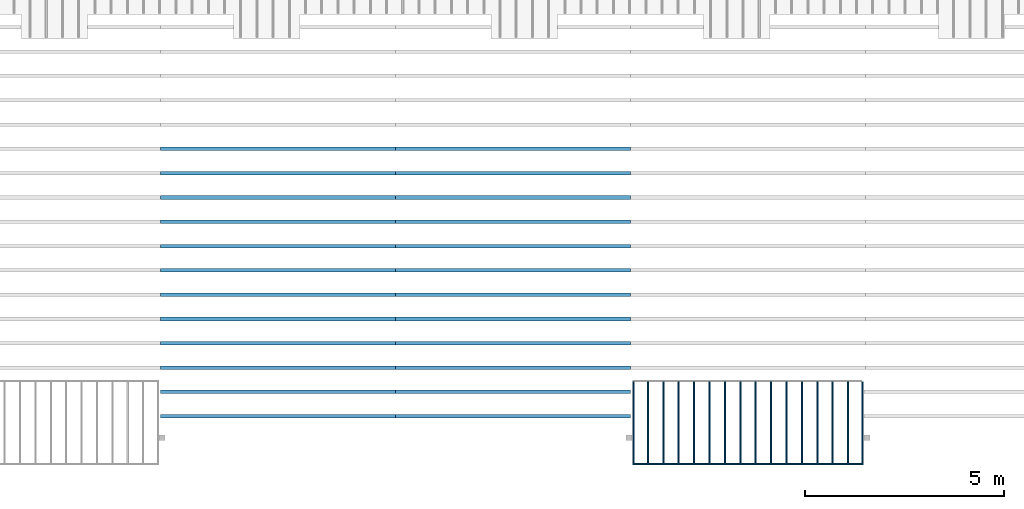
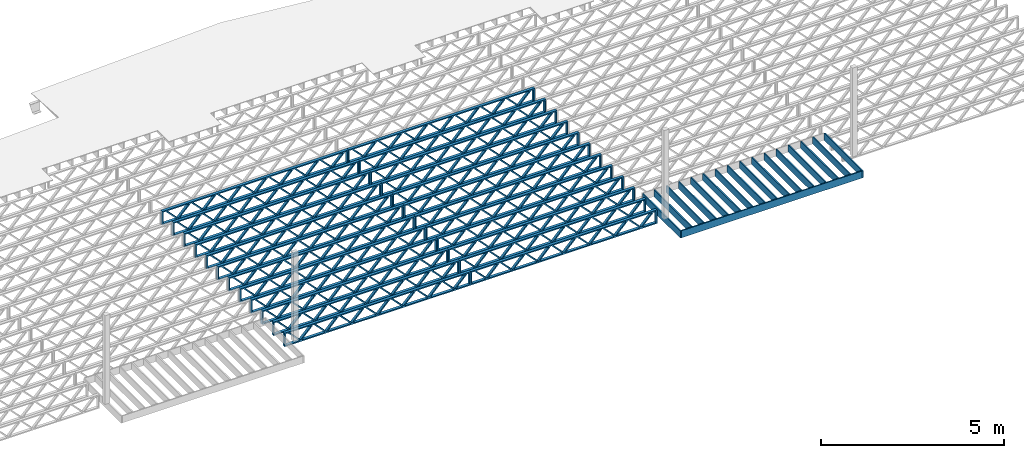
# One storey, part 6 of 12: 41 beams, 3 elements without a shape of their own.
"""IFC4 building model written with IfcOpenShell, lengths in feet."""

import ifcopenshell
import ifcopenshell.guid

model = None  # the IFC model being written
_history = None  # IfcOwnerHistory: only IFC2X3 demands one
_inside = {}  # id of a spatial element -> (the spatial element, [elements in it])
_under = {}  # id of a project, library or spatial element -> (it, [spatial elements below it])
_declared = {}  # id of a project -> (the project, [libraries it declares])
_typed = {}  # id of a type object -> (the type object, [elements of that type])
_made_of = {}  # id of a material, layer set ... -> (it, [elements and type objects made of it])


def new_model(schema):
    """Start an empty IFC model of exactly this schema.

    Asked for "IFC4X3", IfcOpenShell would pick the latest addendum, in which some entities
    have other attributes; the version numbers below select the first issue.
    IFC2X3 requires an IfcOwnerHistory on every rooted entity: one is made here for all.
    """
    global model, _history
    if schema == "IFC4X3":
        model = ifcopenshell.file(schema_version=(4, 3, 0, 0))
    else:
        model = ifcopenshell.file(schema=schema)
    _inside.clear()
    _under.clear()
    _declared.clear()
    _typed.clear()
    _made_of.clear()
    _history = None
    if model.schema == "IFC2X3":
        org = make("IfcOrganization", Name="unknown")
        user = make(
            "IfcPersonAndOrganization",
            ThePerson=make("IfcPerson", FamilyName="unknown"),
            TheOrganization=org,
        )
        app = make(
            "IfcApplication",
            ApplicationDeveloper=org,
            Version="unknown",
            ApplicationFullName="unknown",
            ApplicationIdentifier="unknown",
        )
        _history = make(
            "IfcOwnerHistory",
            OwningUser=user,
            OwningApplication=app,
            ChangeAction="ADDED",
            CreationDate=0,
        )
    return model


def make(cls, **values):
    """One entity of the class cls with the attributes given. An attribute that is None is left unset."""
    return model.create_entity(
        cls, **{name: value for name, value in values.items() if value is not None}
    )


def entity(cls, *values):
    """Any entity or typed value of the class cls, its attributes in the order of the schema. None: left unset."""
    e = model.create_entity(cls)
    for i, value in enumerate(values):
        if value is not None:
            e[i] = value
    return e


def rooted(cls, **values):
    """An entity with a GlobalId (a new one), such as an element, a storey or a relation."""
    return make(cls, GlobalId=ifcopenshell.guid.new(), OwnerHistory=_history, **values)


def si_unit(unit_type, name, prefix=None):
    """IfcSIUnit, for example si_unit("LENGTHUNIT", "METRE", prefix="MILLI")."""
    return make("IfcSIUnit", UnitType=unit_type, Prefix=prefix, Name=name)


def converted_unit(unit_type, name, factor, base, dimensions=None, offset=None):
    """IfcConversionBasedUnit, such as the inch: factor (a typed value) times the base unit."""
    return make(
        "IfcConversionBasedUnit"
        if offset is None
        else "IfcConversionBasedUnitWithOffset",
        ConversionOffset=offset,
        Dimensions=None
        if dimensions is None
        else entity("IfcDimensionalExponents", *dimensions),
        UnitType=unit_type,
        Name=name,
        ConversionFactor=make(
            "IfcMeasureWithUnit", ValueComponent=factor, UnitComponent=base
        ),
    )


def derived_unit(unit_type, elements):
    """IfcDerivedUnit: a product of units, each with its exponent."""
    return make(
        "IfcDerivedUnit",
        Elements=[
            make("IfcDerivedUnitElement", Unit=unit, Exponent=power)
            for unit, power in elements
        ],
        UnitType=unit_type,
    )


def assignment(units):
    """IfcUnitAssignment: the units of a project."""
    return None if units is None else make("IfcUnitAssignment", Units=units)


def point(xyz):
    """IfcCartesianPoint."""
    return None if xyz is None else make("IfcCartesianPoint", Coordinates=xyz)


def direction(xyz):
    """IfcDirection."""
    return None if xyz is None else make("IfcDirection", DirectionRatios=xyz)


def frame(location, z_axis=None, x_axis=None):
    """IfcAxis2Placement3D, a coordinate frame: its origin and axes. An axis left out is left unset."""
    return make(
        "IfcAxis2Placement3D",
        Location=point(location),
        Axis=direction(z_axis),
        RefDirection=direction(x_axis),
    )


def frame_2d(location, x_axis=None):
    """IfcAxis2Placement2D, a coordinate frame in the plane: its origin and x axis."""
    return make(
        "IfcAxis2Placement2D", Location=point(location), RefDirection=direction(x_axis)
    )


def origin():
    """The frame at (0, 0, 0) with its axes left unset."""
    return frame((0.0, 0.0, 0.0))


def origin_2d_with_axis():
    """The frame at (0, 0) in the plane with the x axis (1, 0) written out."""
    return frame_2d((0.0, 0.0), x_axis=(1.0, 0.0))


def place(relative_to, where):
    """IfcLocalPlacement: puts the frame where relative to a parent placement (None: the world)."""
    return make(
        "IfcLocalPlacement", PlacementRelTo=relative_to, RelativePlacement=where
    )


def context(
    kind, dimensions, precision=None, world=None, true_north=None, identifier=None
):
    """IfcGeometricRepresentationContext, for example the 3D "Model" context."""
    return make(
        "IfcGeometricRepresentationContext",
        ContextIdentifier=identifier,
        ContextType=kind,
        CoordinateSpaceDimension=dimensions,
        Precision=precision,
        WorldCoordinateSystem=world,
        TrueNorth=true_north,
    )


def subcontext(parent, identifier, kind, view, scale=None):
    """IfcGeometricRepresentationSubContext, for example "Body" below "Model"."""
    return make(
        "IfcGeometricRepresentationSubContext",
        ContextIdentifier=identifier,
        ContextType=kind,
        ParentContext=parent,
        TargetScale=scale,
        TargetView=view,
    )


def project(units=None, contexts=None):
    """IfcProject with its units and contexts."""
    return rooted(
        "IfcProject",
        Name="project",
        RepresentationContexts=contexts,
        UnitsInContext=assignment(units),
    )


def spatial(cls, under=None, at=None, **own):
    """A site, building, storey or space (cls), placed at a placement, below another one or the project."""
    s = rooted(cls, ObjectPlacement=at, **own)
    if under is not None:
        _under.setdefault(under.id(), (under, []))[1].append(s)
    return s


def profile(cls, at=None, kind="AREA", **sizes):
    """A parametric profile (cls). Its sizes go by their IFC names, for example OverallWidth=200.0."""
    return make(cls, ProfileType=kind, Position=at, **sizes)


def rectangle(**sizes):
    """IfcRectangleProfileDef."""
    return profile("IfcRectangleProfileDef", **sizes)


def extrude(swept, where, along, depth):
    """IfcExtrudedAreaSolid: the profile swept, set in the frame where, extruded along a direction by depth."""
    return make(
        "IfcExtrudedAreaSolid",
        SweptArea=swept,
        Position=where,
        ExtrudedDirection=direction(along),
        Depth=depth,
    )


def shape(context_of_items, identifier, shape_type, items):
    """IfcShapeRepresentation: the items that make up one representation, for example the "Body"."""
    return make(
        "IfcShapeRepresentation",
        ContextOfItems=context_of_items,
        RepresentationIdentifier=identifier,
        RepresentationType=shape_type,
        Items=items,
    )


def source(mapping_origin, context_of_items, identifier, shape_type, items):
    """IfcRepresentationMap: a shape defined once, which mapped items show again and again."""
    return make(
        "IfcRepresentationMap",
        MappingOrigin=mapping_origin,
        MappedRepresentation=shape(context_of_items, identifier, shape_type, items),
    )


def transform(
    local_origin,
    x_axis=None,
    y_axis=None,
    z_axis=None,
    scale=None,
    scale2=None,
    scale3=None,
    uniform=True,
):
    """IfcCartesianTransformationOperator3D, or its non-uniform kind. x_axis, y_axis, z_axis: its Axis1, 2, 3."""
    if uniform:
        return make(
            "IfcCartesianTransformationOperator3D",
            Axis1=direction(x_axis),
            Axis2=direction(y_axis),
            LocalOrigin=point(local_origin),
            Scale=scale,
            Axis3=direction(z_axis),
        )
    return make(
        "IfcCartesianTransformationOperator3DnonUniform",
        Axis1=direction(x_axis),
        Axis2=direction(y_axis),
        LocalOrigin=point(local_origin),
        Scale=scale,
        Axis3=direction(z_axis),
        Scale2=scale2,
        Scale3=scale3,
    )


def mapped(mapping_source, mapping_target):
    """IfcMappedItem: shows the shape of a source again, moved by a transform."""
    return make(
        "IfcMappedItem", MappingSource=mapping_source, MappingTarget=mapping_target
    )


def material(Name=None, Category=None):
    """IfcMaterial."""
    return make("IfcMaterial", Name=Name, Category=Category)


def material_profile(
    of_material, cross_section, Name=None, Category=None, Priority=None
):
    """IfcMaterialProfile: a cross section and its material."""
    return make(
        "IfcMaterialProfile",
        Name=Name,
        Material=of_material,
        Profile=cross_section,
        Priority=Priority,
        Category=Category,
    )


def profile_set(profiles, Name=None, composite=None):
    """IfcMaterialProfileSet."""
    return make(
        "IfcMaterialProfileSet",
        Name=Name,
        MaterialProfiles=profiles,
        CompositeProfile=composite,
    )


def profile_usage(for_profile_set, cardinal=None, extent=None):
    """IfcMaterialProfileSetUsage: how a profile set lies along its element."""
    return make(
        "IfcMaterialProfileSetUsage",
        ForProfileSet=for_profile_set,
        CardinalPoint=cardinal,
        ReferenceExtent=extent,
    )


def made_of(thing, what):
    """Note that an element or type object is made of a material, layer set ...; save() writes the relation."""
    if what is not None:
        _made_of.setdefault(what.id(), (what, []))[1].append(thing)
    return thing


def type_object(cls, material=None, **own):
    """A type object (cls), such as IfcWallType, which elements share."""
    return made_of(rooted(cls, **own), material)


def type_shapes(of_type, sources):
    """Give a type object the sources (RepresentationMaps) that its elements show as mapped items."""
    of_type.RepresentationMaps = sources


def element(
    cls,
    number,
    at=None,
    inside=None,
    cuts=None,
    type_object=None,
    material=None,
    context=None,
    identifier="Body",
    shape_type=None,
    held_by="IfcProductDefinitionShape",
    body=None,
    shapes=None,
    **own,
):
    """One element of the class cls, such as IfcWall. Its Tag is "e" and its number.

    at: its placement. inside: the storey or other place that contains it. cuts: it is an
    opening in that element (IfcRelVoidsElement). A single representation is given by context,
    identifier, shape_type and body (its items); several are given by shapes. held_by: the class
    of the entity that holds the representations. save() writes the other relations.
    """
    e = rooted(cls, Tag="e%d" % number, ObjectPlacement=at, **own)
    if body is not None:
        shapes = [shape(context, identifier, shape_type, body)]
    if shapes is not None:
        e.Representation = make(held_by, Representations=shapes)
    if inside is not None:
        _inside.setdefault(inside.id(), (inside, []))[1].append(e)
    if cuts is not None:
        rooted(
            "IfcRelVoidsElement", RelatingBuildingElement=cuts, RelatedOpeningElement=e
        )
    if type_object is not None:
        _typed.setdefault(type_object.id(), (type_object, []))[1].append(e)
    return made_of(e, material)


def aggregate(whole, parts):
    """IfcRelAggregates: a whole, such as a stair, and the parts it consists of."""
    return rooted("IfcRelAggregates", RelatingObject=whole, RelatedObjects=parts)


def save(model, path):
    """Write the relations noted so far, then the file.

    IfcRelAggregates (storeys below a building ...), IfcRelContainedInSpatialStructure (elements
    in a storey), IfcRelDefinesByType, IfcRelAssociatesMaterial and IfcRelDeclares: one each for
    every whole, place, type object, material and project.
    """
    for whole, parts in _under.values():
        aggregate(whole, parts)
    for where, things in _inside.values():
        rooted(
            "IfcRelContainedInSpatialStructure",
            RelatedElements=things,
            RelatingStructure=where,
        )
    for kind, things in _typed.values():
        rooted("IfcRelDefinesByType", RelatedObjects=things, RelatingType=kind)
    for what, things in _made_of.values():
        rooted("IfcRelAssociatesMaterial", RelatedObjects=things, RelatingMaterial=what)
    for by, libraries in _declared.values():
        rooted("IfcRelDeclares", RelatingContext=by, RelatedDefinitions=libraries)
    model.write(path)


model = new_model("IFC4")

# Units and contexts
model_context = context("Model", 3, precision=0.0001, world=origin(), true_north=direction((6.12303176911189e-17, 1.0)))
body_context = subcontext(model_context, "Body", "Model", "MODEL_VIEW")
ifc_project = project(units=[converted_unit("LENGTHUNIT", "FOOT", entity("IfcRatioMeasure", 0.3048), si_unit("LENGTHUNIT", "METRE"), dimensions=[1, 0, 0, 0, 0, 0, 0]), converted_unit("AREAUNIT", "SQUARE FOOT", entity("IfcRatioMeasure", 0.09290304), si_unit("AREAUNIT", "SQUARE_METRE"), dimensions=[2, 0, 0, 0, 0, 0, 0]), converted_unit("VOLUMEUNIT", "CUBIC FOOT", entity("IfcRatioMeasure", 0.028316846592), si_unit("VOLUMEUNIT", "CUBIC_METRE"), dimensions=[3, 0, 0, 0, 0, 0, 0]), converted_unit("PLANEANGLEUNIT", "DEGREE", entity("IfcRatioMeasure", 0.0174532925199433), si_unit("PLANEANGLEUNIT", "RADIAN"), dimensions=[0, 0, 0, 0, 0, 0, 0]), si_unit("MASSUNIT", "GRAM", prefix="KILO"), derived_unit("MASSDENSITYUNIT", [(si_unit("MASSUNIT", "GRAM", prefix="KILO"), 1), (si_unit("LENGTHUNIT", "METRE"), -3)]), derived_unit("MOMENTOFINERTIAUNIT", [(si_unit("LENGTHUNIT", "METRE"), 4)]), si_unit("TIMEUNIT", "SECOND"), si_unit("FREQUENCYUNIT", "HERTZ"), si_unit("THERMODYNAMICTEMPERATUREUNIT", "DEGREE_CELSIUS"), derived_unit("THERMALTRANSMITTANCEUNIT", [(si_unit("MASSUNIT", "GRAM", prefix="KILO"), 1), (si_unit("THERMODYNAMICTEMPERATUREUNIT", "KELVIN"), -1), (si_unit("TIMEUNIT", "SECOND"), -3)]), derived_unit("VOLUMETRICFLOWRATEUNIT", [(si_unit("LENGTHUNIT", "METRE"), 3), (si_unit("TIMEUNIT", "SECOND"), -1)]), si_unit("ELECTRICCURRENTUNIT", "AMPERE"), si_unit("ELECTRICVOLTAGEUNIT", "VOLT"), si_unit("POWERUNIT", "WATT"), si_unit("FORCEUNIT", "NEWTON"), si_unit("ILLUMINANCEUNIT", "LUX"), si_unit("LUMINOUSFLUXUNIT", "LUMEN"), si_unit("LUMINOUSINTENSITYUNIT", "CANDELA"), derived_unit("USERDEFINED", [(si_unit("MASSUNIT", "GRAM", prefix="KILO"), -1), (si_unit("LENGTHUNIT", "METRE"), -2), (si_unit("TIMEUNIT", "SECOND"), 3), (si_unit("LUMINOUSFLUXUNIT", "LUMEN"), 1)]), derived_unit("LINEARVELOCITYUNIT", [(si_unit("LENGTHUNIT", "METRE"), 1), (si_unit("TIMEUNIT", "SECOND"), -1)]), si_unit("PRESSUREUNIT", "PASCAL"), derived_unit("USERDEFINED", [(si_unit("LENGTHUNIT", "METRE"), -2), (si_unit("MASSUNIT", "GRAM", prefix="KILO"), 1), (si_unit("TIMEUNIT", "SECOND"), -2)]), derived_unit("LINEARFORCEUNIT", [(si_unit("MASSUNIT", "GRAM", prefix="KILO"), 1), (si_unit("LENGTHUNIT", "METRE"), 1), (si_unit("TIMEUNIT", "SECOND"), -2), (si_unit("LENGTHUNIT", "METRE"), -1)]), derived_unit("PLANARFORCEUNIT", [(si_unit("MASSUNIT", "GRAM", prefix="KILO"), 1), (si_unit("LENGTHUNIT", "METRE"), 1), (si_unit("TIMEUNIT", "SECOND"), -2), (si_unit("LENGTHUNIT", "METRE"), -2)])], contexts=[model_context])

# Site, building, storey
site_placement = place(None, origin())
site = spatial("IfcSite", under=ifc_project, at=site_placement, CompositionType="ELEMENT")
building_placement = place(site_placement, origin())
building = spatial("IfcBuilding", under=site, at=building_placement, CompositionType="ELEMENT")
storey_placement = place(building_placement, frame((0.0, 0.0, 21.46875)))
storey = spatial("IfcBuildingStorey", under=building, at=storey_placement, Name="3RD FLOOR", CompositionType="ELEMENT", Elevation=21.46875)

# Assembly, beams
assembly_1_placement = place(storey_placement, origin())
assembly_1 = element("IfcElementAssembly", 1, at=assembly_1_placement, inside=storey, Name="Structural Beam System:Structural Framing System", ObjectType="Structural Beam System:Structural Framing System", AssemblyPlace="NOTDEFINED", PredefinedType="BEAM_GRID")
ifc_material_1 = material(Category="Materials")
ifc_material_profile_1 = material_profile(ifc_material_1, rectangle(XDim=0.770833333333333, YDim=0.124999999999994, at=frame_2d((-5.55111512312578e-17, 0.0), x_axis=(1.0, 0.0))))
ifc_profile_set_1 = profile_set([ifc_material_profile_1])
ifc_profile_usage_1 = profile_usage(ifc_profile_set_1, cardinal=8)
beam_type_1 = type_object("IfcBeamType", PredefinedType="BEAM", material=ifc_profile_set_1)
shared_shape_1 = source(origin(), body_context, "Body", "SweptSolid", [
    extrude(rectangle(XDim=0.770833333333333, YDim=0.124999999999994, at=frame_2d((-5.55111512312578e-17, 0.0), x_axis=(1.0, 0.0))), frame((-3.35416666666737, 0.0, 0.0), z_axis=(1.0, 0.0, 0.0), x_axis=(0.0, 0.0, -1.0)), (0.0, 0.0, 1.0), 6.70833333333462),
])
type_shapes(beam_type_1, [shared_shape_1])
beam_1_placement = place(assembly_1_placement, frame((-165.835122291113, 925.341101549316, -0.645833333333474), z_axis=(0.0, 0.0, 1.0), x_axis=(0.0, 1.0, 0.0)))
beam_1 = element("IfcBeam", 2, at=beam_1_placement, type_object=beam_type_1, material=ifc_profile_usage_1, PredefinedType="BEAM", context=body_context, shape_type="MappedRepresentation", body=[
    mapped(shared_shape_1, transform((0.0, 0.0, 0.0), scale=1.0)),
])
ifc_profile_usage_2 = profile_usage(ifc_profile_set_1, cardinal=8)
beam_2_placement = place(assembly_1_placement, frame((-167.102005971671, 925.341101549316, -0.645833333333474), z_axis=(0.0, 0.0, 1.0), x_axis=(0.0, 1.0, 0.0)))
beam_2 = element("IfcBeam", 3, at=beam_2_placement, type_object=beam_type_1, material=ifc_profile_usage_2, PredefinedType="BEAM", context=body_context, shape_type="MappedRepresentation", body=[
    mapped(shared_shape_1, transform((0.0, 0.0, 0.0), scale=1.0)),
])
ifc_profile_usage_3 = profile_usage(ifc_profile_set_1, cardinal=8)
beam_3_placement = place(assembly_1_placement, frame((-168.368889652229, 925.341101549316, -0.645833333333474), z_axis=(0.0, 0.0, 1.0), x_axis=(0.0, 1.0, 0.0)))
beam_3 = element("IfcBeam", 4, at=beam_3_placement, type_object=beam_type_1, material=ifc_profile_usage_3, PredefinedType="BEAM", context=body_context, shape_type="MappedRepresentation", body=[
    mapped(shared_shape_1, transform((0.0, 0.0, 0.0), scale=1.0)),
])
ifc_profile_usage_4 = profile_usage(ifc_profile_set_1, cardinal=8)
beam_4_placement = place(assembly_1_placement, frame((-169.635773332788, 925.341101549317, -0.645833333333474), z_axis=(0.0, 0.0, 1.0), x_axis=(0.0, 1.0, 0.0)))
beam_4 = element("IfcBeam", 5, at=beam_4_placement, type_object=beam_type_1, material=ifc_profile_usage_4, PredefinedType="BEAM", context=body_context, shape_type="MappedRepresentation", body=[
    mapped(shared_shape_1, transform((0.0, 0.0, 0.0), scale=1.0)),
])
ifc_profile_usage_5 = profile_usage(ifc_profile_set_1, cardinal=8)
beam_5_placement = place(assembly_1_placement, frame((-170.902657013346, 925.341101549317, -0.645833333333474), z_axis=(0.0, 0.0, 1.0), x_axis=(0.0, 1.0, 0.0)))
beam_5 = element("IfcBeam", 6, at=beam_5_placement, type_object=beam_type_1, material=ifc_profile_usage_5, PredefinedType="BEAM", context=body_context, shape_type="MappedRepresentation", body=[
    mapped(shared_shape_1, transform((0.0, 0.0, 0.0), scale=1.0)),
])
ifc_profile_usage_6 = profile_usage(ifc_profile_set_1, cardinal=8)
beam_6_placement = place(assembly_1_placement, frame((-172.169540693904, 925.341101549317, -0.645833333333474), z_axis=(0.0, 0.0, 1.0), x_axis=(0.0, 1.0, 0.0)))
beam_6 = element("IfcBeam", 7, at=beam_6_placement, type_object=beam_type_1, material=ifc_profile_usage_6, PredefinedType="BEAM", context=body_context, shape_type="MappedRepresentation", body=[
    mapped(shared_shape_1, transform((0.0, 0.0, 0.0), scale=1.0)),
])
ifc_profile_usage_7 = profile_usage(ifc_profile_set_1, cardinal=8)
beam_7_placement = place(assembly_1_placement, frame((-173.436424374463, 925.341101549317, -0.645833333333474), z_axis=(0.0, 0.0, 1.0), x_axis=(0.0, 1.0, 0.0)))
beam_7 = element("IfcBeam", 8, at=beam_7_placement, type_object=beam_type_1, material=ifc_profile_usage_7, PredefinedType="BEAM", context=body_context, shape_type="MappedRepresentation", body=[
    mapped(shared_shape_1, transform((0.0, 0.0, 0.0), scale=1.0)),
])
ifc_profile_usage_8 = profile_usage(ifc_profile_set_1, cardinal=8)
beam_8_placement = place(assembly_1_placement, frame((-174.703308055021, 925.341101549318, -0.645833333333435), z_axis=(0.0, 0.0, 1.0), x_axis=(0.0, 1.0, 0.0)))
beam_8 = element("IfcBeam", 9, at=beam_8_placement, type_object=beam_type_1, material=ifc_profile_usage_8, PredefinedType="BEAM", context=body_context, shape_type="MappedRepresentation", body=[
    mapped(shared_shape_1, transform((0.0, 0.0, 0.0), scale=1.0)),
])
ifc_profile_usage_9 = profile_usage(ifc_profile_set_1, cardinal=8)
beam_9_placement = place(assembly_1_placement, frame((-175.970191735579, 925.341101549318, -0.645833333333474), z_axis=(0.0, 0.0, 1.0), x_axis=(0.0, 1.0, 0.0)))
beam_9 = element("IfcBeam", 10, at=beam_9_placement, type_object=beam_type_1, material=ifc_profile_usage_9, PredefinedType="BEAM", context=body_context, shape_type="MappedRepresentation", body=[
    mapped(shared_shape_1, transform((0.0, 0.0, 0.0), scale=1.0)),
])
ifc_profile_usage_10 = profile_usage(ifc_profile_set_1, cardinal=8)
beam_10_placement = place(assembly_1_placement, frame((-177.237075416138, 925.341101549318, -0.645833333333474), z_axis=(0.0, 0.0, 1.0), x_axis=(0.0, 1.0, 0.0)))
beam_10 = element("IfcBeam", 11, at=beam_10_placement, type_object=beam_type_1, material=ifc_profile_usage_10, PredefinedType="BEAM", context=body_context, shape_type="MappedRepresentation", body=[
    mapped(shared_shape_1, transform((0.0, 0.0, 0.0), scale=1.0)),
])
ifc_profile_usage_11 = profile_usage(ifc_profile_set_1, cardinal=8)
beam_11_placement = place(assembly_1_placement, frame((-178.503959096696, 925.341101549318, -0.645833333333474), z_axis=(0.0, 0.0, 1.0), x_axis=(0.0, 1.0, 0.0)))
beam_11 = element("IfcBeam", 12, at=beam_11_placement, type_object=beam_type_1, material=ifc_profile_usage_11, PredefinedType="BEAM", context=body_context, shape_type="MappedRepresentation", body=[
    mapped(shared_shape_1, transform((0.0, 0.0, 0.0), scale=1.0)),
])
ifc_profile_usage_12 = profile_usage(ifc_profile_set_1, cardinal=8)
beam_12_placement = place(assembly_1_placement, frame((-179.770842777255, 925.341101549318, -0.645833333333474), z_axis=(0.0, 0.0, 1.0), x_axis=(0.0, 1.0, 0.0)))
beam_12 = element("IfcBeam", 13, at=beam_12_placement, type_object=beam_type_1, material=ifc_profile_usage_12, PredefinedType="BEAM", context=body_context, shape_type="MappedRepresentation", body=[
    mapped(shared_shape_1, transform((0.0, 0.0, 0.0), scale=1.0)),
])
ifc_profile_usage_13 = profile_usage(ifc_profile_set_1, cardinal=8)
beam_13_placement = place(assembly_1_placement, frame((-181.037726457813, 925.341101549318, -0.645833333333474), z_axis=(0.0, 0.0, 1.0), x_axis=(0.0, 1.0, 0.0)))
beam_13 = element("IfcBeam", 14, at=beam_13_placement, type_object=beam_type_1, material=ifc_profile_usage_13, PredefinedType="BEAM", context=body_context, shape_type="MappedRepresentation", body=[
    mapped(shared_shape_1, transform((0.0, 0.0, 0.0), scale=1.0)),
])
ifc_profile_usage_14 = profile_usage(ifc_profile_set_1, cardinal=8)
beam_14_placement = place(assembly_1_placement, frame((-182.304610138371, 925.341101549319, -0.645833333333474), z_axis=(0.0, 0.0, 1.0), x_axis=(0.0, 1.0, 0.0)))
beam_14 = element("IfcBeam", 15, at=beam_14_placement, type_object=beam_type_1, material=ifc_profile_usage_14, PredefinedType="BEAM", context=body_context, shape_type="MappedRepresentation", body=[
    mapped(shared_shape_1, transform((0.0, 0.0, 0.0), scale=1.0)),
])
aggregate(assembly_1, [beam_1, beam_2, beam_3, beam_4, beam_5, beam_6, beam_7, beam_8, beam_9, beam_10, beam_11, beam_12, beam_13, beam_14])

assembly_2_placement = place(storey_placement, origin())
assembly_2 = element("IfcElementAssembly", 16, at=assembly_2_placement, inside=storey, Name="Structural Beam System:Structural Framing System", ObjectType="Structural Beam System:Structural Framing System", AssemblyPlace="NOTDEFINED", PredefinedType="BEAM_GRID")
ifc_material_2 = material(Name="WOOD TRUSS", Category="Materials")
ifc_material_profile_2 = material_profile(ifc_material_2, rectangle(XDim=1.73473973950632, YDim=0.125, at=frame_2d((-1.11022302462516e-16, 8.32667268468867e-17), x_axis=(1.0, 0.0))))
ifc_material_profile_3 = material_profile(ifc_material_2, rectangle(XDim=1.73473973950633, YDim=0.125, at=frame_2d((-1.11022302462516e-16, 8.32667268468867e-17), x_axis=(1.0, 0.0))))
ifc_material_profile_4 = material_profile(ifc_material_2, rectangle(XDim=1.73473973950632, YDim=0.125, at=frame_2d((-5.55111512312578e-17, 1.38777878078145e-16), x_axis=(1.0, 0.0))))
ifc_material_profile_5 = material_profile(ifc_material_2, rectangle(XDim=1.73473973950633, YDim=0.125, at=frame_2d((-1.11022302462516e-16, 8.32667268468867e-17), x_axis=(1.0, 0.0))))
ifc_material_profile_6 = material_profile(ifc_material_2, rectangle(XDim=1.73473973950632, YDim=0.125, at=frame_2d((-1.11022302462516e-16, 8.32667268468867e-17), x_axis=(1.0, 0.0))))
ifc_material_profile_7 = material_profile(ifc_material_2, rectangle(XDim=1.73473973950633, YDim=0.125, at=frame_2d((-2.77555756156289e-16, 3.05311331771918e-16), x_axis=(1.0, 0.0))))
ifc_material_profile_8 = material_profile(ifc_material_2, rectangle(XDim=1.73473973950632, YDim=0.124999999999999, at=frame_2d((-3.88578058618805e-16, -2.4980018054066e-16), x_axis=(1.0, 0.0))))
ifc_material_profile_9 = material_profile(ifc_material_2, rectangle(XDim=1.73473973950633, YDim=0.125, at=frame_2d((2.77555756156289e-16, -3.05311331771918e-16), x_axis=(1.0, 0.0))))
ifc_material_profile_10 = material_profile(ifc_material_2, rectangle(XDim=1.73473973950632, YDim=0.124999999999999, at=frame_2d((-1.11022302462516e-16, 8.32667268468867e-17), x_axis=(1.0, 0.0))))
ifc_material_profile_11 = material_profile(ifc_material_2, rectangle(XDim=1.73473973950633, YDim=0.125, at=origin_2d_with_axis()))
ifc_material_profile_12 = material_profile(ifc_material_2, rectangle(XDim=0.124999999999982, YDim=0.291666666666668, at=origin_2d_with_axis()))
ifc_material_profile_13 = material_profile(ifc_material_2, rectangle(XDim=0.124999999999932, YDim=0.291666666666664, at=origin_2d_with_axis()))
ifc_material_profile_14 = material_profile(ifc_material_2, rectangle(XDim=1.25000000000002, YDim=0.29166666666667, at=origin_2d_with_axis()))
ifc_material_profile_15 = material_profile(ifc_material_2, rectangle(XDim=1.25000000000004, YDim=0.291666666666667, at=origin_2d_with_axis()))
ifc_profile_set_2 = profile_set([ifc_material_profile_2, ifc_material_profile_3, ifc_material_profile_4, ifc_material_profile_5, ifc_material_profile_6, ifc_material_profile_7, ifc_material_profile_8, ifc_material_profile_9, ifc_material_profile_10, ifc_material_profile_11, ifc_material_profile_12, ifc_material_profile_13, ifc_material_profile_14, ifc_material_profile_15])
ifc_profile_usage_15 = profile_usage(ifc_profile_set_2, cardinal=8)
beam_type_2 = type_object("IfcBeamType", PredefinedType="BEAM", material=ifc_profile_set_2)
shared_shape_2 = source(origin(), body_context, "Body", "SweptSolid", [
    extrude(rectangle(XDim=1.73473973950632, YDim=0.124999999999999, at=frame_2d((5.55111512312578e-16, 7.21644966006352e-16), x_axis=(1.0, 0.0))), frame((5.95847627016997, -0.145833333333334, 0.0), z_axis=(0.0, 1.0, 0.0), x_axis=(0.693383046997606, 0.0, 0.720569184836762)), (0.0, 0.0, 1.0), 0.291666666666667),
    extrude(rectangle(XDim=1.73473973950633, YDim=0.125, at=origin_2d_with_axis()), frame((4.7081903964967, -0.145833333333334, 0.0), z_axis=(0.0, 1.0, 0.0), x_axis=(0.69338304699761, 0.0, -0.720569184836758)), (0.0, 0.0, 1.0), 0.291666666666666),
    extrude(rectangle(XDim=1.73473973950632, YDim=0.125, at=frame_2d((2.22044604925031e-16, 3.88578058618805e-16), x_axis=(1.0, 0.0))), frame((3.29180960350347, -0.145833333333334, 0.0), z_axis=(0.0, 1.0, 0.0), x_axis=(0.693383046997606, 0.0, 0.720569184836762)), (0.0, 0.0, 1.0), 0.291666666666667),
    extrude(rectangle(XDim=1.73473973950633, YDim=0.125, at=frame_2d((1.11022302462516e-16, -8.32667268468867e-17), x_axis=(1.0, 0.0))), frame((2.0415237298302, -0.145833333333334, 0.0), z_axis=(0.0, 1.0, 0.0), x_axis=(0.69338304699761, 0.0, -0.720569184836758)), (0.0, 0.0, 1.0), 0.291666666666667),
    extrude(rectangle(XDim=1.73473973950632, YDim=0.125, at=frame_2d((-5.55111512312578e-17, 1.38777878078145e-16), x_axis=(1.0, 0.0))), frame((0.625142936836964, -0.145833333333334, 0.0), z_axis=(0.0, 1.0, 0.0), x_axis=(0.693383046997606, 0.0, 0.720569184836762)), (0.0, 0.0, 1.0), 0.291666666666667),
    extrude(rectangle(XDim=1.73473973950633, YDim=0.125, at=frame_2d((-1.11022302462516e-16, 8.32667268468867e-17), x_axis=(1.0, 0.0))), frame((-0.625142936836306, -0.145833333333334, 0.0), z_axis=(0.0, 1.0, 0.0), x_axis=(0.69338304699761, 0.0, -0.720569184836758)), (0.0, 0.0, 1.0), 0.291666666666667),
    extrude(rectangle(XDim=1.73473973950632, YDim=0.125, at=frame_2d((-1.11022302462516e-16, 8.32667268468867e-17), x_axis=(1.0, 0.0))), frame((-2.04152372982954, -0.145833333333334, 0.0), z_axis=(0.0, 1.0, 0.0), x_axis=(0.693383046997606, 0.0, 0.720569184836762)), (0.0, 0.0, 1.0), 0.291666666666667),
    extrude(rectangle(XDim=1.73473973950633, YDim=0.125, at=origin_2d_with_axis()), frame((-3.29180960350281, -0.145833333333334, 0.0), z_axis=(0.0, 1.0, 0.0), x_axis=(0.69338304699761, 0.0, -0.720569184836758)), (0.0, 0.0, 1.0), 0.291666666666667),
    extrude(rectangle(XDim=1.73473973950632, YDim=0.124999999999999, at=frame_2d((-1.11022302462516e-16, 8.32667268468867e-17), x_axis=(1.0, 0.0))), frame((-4.70819039649604, -0.145833333333334, 0.0), z_axis=(0.0, 1.0, 0.0), x_axis=(0.693383046997606, 0.0, 0.720569184836762)), (0.0, 0.0, 1.0), 0.291666666666667),
    extrude(rectangle(XDim=1.73473973950633, YDim=0.125, at=frame_2d((-5.55111512312578e-16, 6.38378239159465e-16), x_axis=(1.0, 0.0))), frame((-5.95847627016931, -0.145833333333334, 0.0), z_axis=(0.0, 1.0, 0.0), x_axis=(0.69338304699761, 0.0, -0.720569184836758)), (0.0, 0.0, 1.0), 0.291666666666666),
    extrude(rectangle(XDim=1.73473973950632, YDim=0.125, at=frame_2d((-7.21644966006352e-16, -5.82867087928207e-16), x_axis=(1.0, 0.0))), frame((8.62514293683647, -0.145833333333334, 0.0), z_axis=(0.0, 1.0, 0.0), x_axis=(0.693383046997607, 0.0, 0.720569184836761)), (0.0, 0.0, 1.0), 0.291666666666667),
    extrude(rectangle(XDim=1.73473973950633, YDim=0.125, at=origin_2d_with_axis()), frame((7.3748570631632, -0.145833333333334, 0.0), z_axis=(0.0, 1.0, 0.0), x_axis=(0.69338304699761, 0.0, -0.720569184836758)), (0.0, 0.0, 1.0), 0.291666666666666),
    extrude(rectangle(XDim=1.73473973950632, YDim=0.124999999999999, at=frame_2d((-1.11022302462516e-16, 8.32667268468867e-17), x_axis=(1.0, 0.0))), frame((-7.37485706316255, -0.145833333333334, 0.0), z_axis=(0.0, 1.0, 0.0), x_axis=(0.693383046997606, 0.0, 0.720569184836762)), (0.0, 0.0, 1.0), 0.291666666666667),
    extrude(rectangle(XDim=1.73473973950633, YDim=0.125, at=origin_2d_with_axis()), frame((-8.62514293683582, -0.145833333333334, 0.0), z_axis=(0.0, 1.0, 0.0), x_axis=(0.69338304699761, 0.0, -0.720569184836758)), (0.0, 0.0, 1.0), 0.291666666666666),
    extrude(rectangle(XDim=0.124999999999982, YDim=0.291666666666668, at=origin_2d_with_axis()), frame((-9.66666666666609, 0.0, 0.687500000000054), z_axis=(1.0, 0.0, 0.0), x_axis=(0.0, 0.0, -1.0)), (0.0, 0.0, 1.0), 19.3333333333322),
    extrude(rectangle(XDim=0.124999999999932, YDim=0.291666666666664, at=origin_2d_with_axis()), frame((-9.66666666666588, 0.0, -0.687499999999984), z_axis=(1.0, 0.0, 0.0), x_axis=(0.0, 0.0, -1.0)), (0.0, 0.0, 1.0), 19.333333333332),
    extrude(rectangle(XDim=1.25000000000002, YDim=0.29166666666667, at=origin_2d_with_axis()), frame((9.54166666666607, 0.0, 0.0), z_axis=(1.0, 0.0, 0.0), x_axis=(0.0, 0.0, -1.0)), (0.0, 0.0, 1.0), 0.12500000000002),
    extrude(rectangle(XDim=1.25000000000004, YDim=0.291666666666667, at=origin_2d_with_axis()), frame((-9.66666666666609, 0.0, 0.0), z_axis=(1.0, 0.0, 0.0), x_axis=(0.0, 0.0, -1.0)), (0.0, 0.0, 1.0), 0.125000000000023),
])
type_shapes(beam_type_2, [shared_shape_2])
beam_15_placement = place(assembly_2_placement, frame((-193.404827152229, 947.861934882651, -0.947916666666881)))
beam_15 = element("IfcBeam", 17, at=beam_15_placement, type_object=beam_type_2, material=ifc_profile_usage_15, PredefinedType="BEAM", context=body_context, shape_type="MappedRepresentation", body=[
    mapped(shared_shape_2, transform((0.0, 0.0, 0.0), scale=1.0)),
])
ifc_profile_usage_16 = profile_usage(ifc_profile_set_2, cardinal=8)
beam_16_placement = place(assembly_2_placement, frame((-193.404827152229, 945.861934882651, -0.947916666666881)))
beam_16 = element("IfcBeam", 18, at=beam_16_placement, type_object=beam_type_2, material=ifc_profile_usage_16, PredefinedType="BEAM", context=body_context, shape_type="MappedRepresentation", body=[
    mapped(shared_shape_2, transform((0.0, 0.0, 0.0), scale=1.0)),
])
ifc_profile_usage_17 = profile_usage(ifc_profile_set_2, cardinal=8)
beam_17_placement = place(assembly_2_placement, frame((-193.404827152229, 943.861934882651, -0.947916666666881)))
beam_17 = element("IfcBeam", 19, at=beam_17_placement, type_object=beam_type_2, material=ifc_profile_usage_17, PredefinedType="BEAM", context=body_context, shape_type="MappedRepresentation", body=[
    mapped(shared_shape_2, transform((0.0, 0.0, 0.0), scale=1.0)),
])
ifc_profile_usage_18 = profile_usage(ifc_profile_set_2, cardinal=8)
beam_18_placement = place(assembly_2_placement, frame((-193.404827152229, 941.861934882651, -0.947916666666881)))
beam_18 = element("IfcBeam", 20, at=beam_18_placement, type_object=beam_type_2, material=ifc_profile_usage_18, PredefinedType="BEAM", context=body_context, shape_type="MappedRepresentation", body=[
    mapped(shared_shape_2, transform((0.0, 0.0, 0.0), scale=1.0)),
])
ifc_profile_usage_19 = profile_usage(ifc_profile_set_2, cardinal=8)
beam_19_placement = place(assembly_2_placement, frame((-193.404827152229, 939.861934882651, -0.947916666666881)))
beam_19 = element("IfcBeam", 21, at=beam_19_placement, type_object=beam_type_2, material=ifc_profile_usage_19, PredefinedType="BEAM", context=body_context, shape_type="MappedRepresentation", body=[
    mapped(shared_shape_2, transform((0.0, 0.0, 0.0), scale=1.0)),
])
ifc_profile_usage_20 = profile_usage(ifc_profile_set_2, cardinal=8)
beam_20_placement = place(assembly_2_placement, frame((-193.404827152229, 937.861934882651, -0.947916666666881)))
beam_20 = element("IfcBeam", 22, at=beam_20_placement, type_object=beam_type_2, material=ifc_profile_usage_20, PredefinedType="BEAM", context=body_context, shape_type="MappedRepresentation", body=[
    mapped(shared_shape_2, transform((0.0, 0.0, 0.0), scale=1.0)),
])
ifc_profile_usage_21 = profile_usage(ifc_profile_set_2, cardinal=8)
beam_21_placement = place(assembly_2_placement, frame((-193.404827152229, 935.861934882651, -0.947916666666881)))
beam_21 = element("IfcBeam", 23, at=beam_21_placement, type_object=beam_type_2, material=ifc_profile_usage_21, PredefinedType="BEAM", context=body_context, shape_type="MappedRepresentation", body=[
    mapped(shared_shape_2, transform((0.0, 0.0, 0.0), scale=1.0)),
])
ifc_profile_usage_22 = profile_usage(ifc_profile_set_2, cardinal=8)
beam_22_placement = place(assembly_2_placement, frame((-193.404827152229, 933.861934882651, -0.947916666666881)))
beam_22 = element("IfcBeam", 24, at=beam_22_placement, type_object=beam_type_2, material=ifc_profile_usage_22, PredefinedType="BEAM", context=body_context, shape_type="MappedRepresentation", body=[
    mapped(shared_shape_2, transform((0.0, 0.0, 0.0), scale=1.0)),
])
ifc_profile_usage_23 = profile_usage(ifc_profile_set_2, cardinal=8)
beam_23_placement = place(assembly_2_placement, frame((-193.404827152229, 931.861934882651, -0.947916666666881)))
beam_23 = element("IfcBeam", 25, at=beam_23_placement, type_object=beam_type_2, material=ifc_profile_usage_23, PredefinedType="BEAM", context=body_context, shape_type="MappedRepresentation", body=[
    mapped(shared_shape_2, transform((0.0, 0.0, 0.0), scale=1.0)),
])
ifc_profile_usage_24 = profile_usage(ifc_profile_set_2, cardinal=8)
beam_24_placement = place(assembly_2_placement, frame((-193.404827152229, 929.861934882651, -0.947916666666881)))
beam_24 = element("IfcBeam", 26, at=beam_24_placement, type_object=beam_type_2, material=ifc_profile_usage_24, PredefinedType="BEAM", context=body_context, shape_type="MappedRepresentation", body=[
    mapped(shared_shape_2, transform((0.0, 0.0, 0.0), scale=1.0)),
])
ifc_profile_usage_25 = profile_usage(ifc_profile_set_2, cardinal=8)
beam_25_placement = place(assembly_2_placement, frame((-193.404827152229, 927.861934882651, -0.947916666666881)))
beam_25 = element("IfcBeam", 27, at=beam_25_placement, type_object=beam_type_2, material=ifc_profile_usage_25, PredefinedType="BEAM", context=body_context, shape_type="MappedRepresentation", body=[
    mapped(shared_shape_2, transform((0.0, 0.0, 0.0), scale=1.0)),
])
ifc_profile_usage_26 = profile_usage(ifc_profile_set_2, cardinal=8)
beam_26_placement = place(assembly_2_placement, frame((-193.404827152229, 925.861934882651, -0.947916666666881)))
beam_26 = element("IfcBeam", 28, at=beam_26_placement, type_object=beam_type_2, material=ifc_profile_usage_26, PredefinedType="BEAM", context=body_context, shape_type="MappedRepresentation", body=[
    mapped(shared_shape_2, transform((0.0, 0.0, 0.0), scale=1.0)),
])
aggregate(assembly_2, [beam_15, beam_16, beam_17, beam_18, beam_19, beam_20, beam_21, beam_22, beam_23, beam_24, beam_25, beam_26])

assembly_3_placement = place(storey_placement, origin())
assembly_3 = element("IfcElementAssembly", 29, at=assembly_3_placement, inside=storey, Name="Structural Beam System:Structural Framing System", ObjectType="Structural Beam System:Structural Framing System", AssemblyPlace="NOTDEFINED", PredefinedType="BEAM_GRID")
ifc_profile_usage_27 = profile_usage(ifc_profile_set_2, cardinal=8)
beam_27_placement = place(assembly_3_placement, frame((-212.738160485495, 947.861934882651, -0.947916666666881), z_axis=(0.0, 0.0, 1.0), x_axis=(-1.0, 0.0, 0.0)))
beam_27 = element("IfcBeam", 30, at=beam_27_placement, type_object=beam_type_2, material=ifc_profile_usage_27, PredefinedType="BEAM", context=body_context, shape_type="MappedRepresentation", body=[
    mapped(shared_shape_2, transform((0.0, 0.0, 0.0), scale=1.0)),
])
ifc_profile_usage_28 = profile_usage(ifc_profile_set_2, cardinal=8)
beam_28_placement = place(assembly_3_placement, frame((-212.738160485495, 945.861934882651, -0.947916666666881), z_axis=(0.0, 0.0, 1.0), x_axis=(-1.0, 0.0, 0.0)))
beam_28 = element("IfcBeam", 31, at=beam_28_placement, type_object=beam_type_2, material=ifc_profile_usage_28, PredefinedType="BEAM", context=body_context, shape_type="MappedRepresentation", body=[
    mapped(shared_shape_2, transform((0.0, 0.0, 0.0), scale=1.0)),
])
ifc_profile_usage_29 = profile_usage(ifc_profile_set_2, cardinal=8)
beam_29_placement = place(assembly_3_placement, frame((-212.738160485495, 943.861934882651, -0.947916666666881), z_axis=(0.0, 0.0, 1.0), x_axis=(-1.0, 0.0, 0.0)))
beam_29 = element("IfcBeam", 32, at=beam_29_placement, type_object=beam_type_2, material=ifc_profile_usage_29, PredefinedType="BEAM", context=body_context, shape_type="MappedRepresentation", body=[
    mapped(shared_shape_2, transform((0.0, 0.0, 0.0), scale=1.0)),
])
ifc_profile_usage_30 = profile_usage(ifc_profile_set_2, cardinal=8)
beam_30_placement = place(assembly_3_placement, frame((-212.738160485495, 941.861934882651, -0.947916666666881), z_axis=(0.0, 0.0, 1.0), x_axis=(-1.0, 0.0, 0.0)))
beam_30 = element("IfcBeam", 33, at=beam_30_placement, type_object=beam_type_2, material=ifc_profile_usage_30, PredefinedType="BEAM", context=body_context, shape_type="MappedRepresentation", body=[
    mapped(shared_shape_2, transform((0.0, 0.0, 0.0), scale=1.0)),
])
ifc_profile_usage_31 = profile_usage(ifc_profile_set_2, cardinal=8)
beam_31_placement = place(assembly_3_placement, frame((-212.738160485495, 939.861934882651, -0.947916666666881), z_axis=(0.0, 0.0, 1.0), x_axis=(-1.0, 0.0, 0.0)))
beam_31 = element("IfcBeam", 34, at=beam_31_placement, type_object=beam_type_2, material=ifc_profile_usage_31, PredefinedType="BEAM", context=body_context, shape_type="MappedRepresentation", body=[
    mapped(shared_shape_2, transform((0.0, 0.0, 0.0), scale=1.0)),
])
ifc_profile_usage_32 = profile_usage(ifc_profile_set_2, cardinal=8)
beam_32_placement = place(assembly_3_placement, frame((-212.738160485495, 937.861934882651, -0.947916666666881), z_axis=(0.0, 0.0, 1.0), x_axis=(-1.0, 0.0, 0.0)))
beam_32 = element("IfcBeam", 35, at=beam_32_placement, type_object=beam_type_2, material=ifc_profile_usage_32, PredefinedType="BEAM", context=body_context, shape_type="MappedRepresentation", body=[
    mapped(shared_shape_2, transform((0.0, 0.0, 0.0), scale=1.0)),
])
ifc_profile_usage_33 = profile_usage(ifc_profile_set_2, cardinal=8)
beam_33_placement = place(assembly_3_placement, frame((-212.738160485495, 935.861934882651, -0.947916666666881), z_axis=(0.0, 0.0, 1.0), x_axis=(-1.0, 0.0, 0.0)))
beam_33 = element("IfcBeam", 36, at=beam_33_placement, type_object=beam_type_2, material=ifc_profile_usage_33, PredefinedType="BEAM", context=body_context, shape_type="MappedRepresentation", body=[
    mapped(shared_shape_2, transform((0.0, 0.0, 0.0), scale=1.0)),
])
ifc_profile_usage_34 = profile_usage(ifc_profile_set_2, cardinal=8)
beam_34_placement = place(assembly_3_placement, frame((-212.738160485495, 933.861934882651, -0.947916666666881), z_axis=(0.0, 0.0, 1.0), x_axis=(-1.0, 0.0, 0.0)))
beam_34 = element("IfcBeam", 37, at=beam_34_placement, type_object=beam_type_2, material=ifc_profile_usage_34, PredefinedType="BEAM", context=body_context, shape_type="MappedRepresentation", body=[
    mapped(shared_shape_2, transform((0.0, 0.0, 0.0), scale=1.0)),
])
ifc_profile_usage_35 = profile_usage(ifc_profile_set_2, cardinal=8)
beam_35_placement = place(assembly_3_placement, frame((-212.738160485495, 931.861934882651, -0.947916666666881), z_axis=(0.0, 0.0, 1.0), x_axis=(-1.0, 0.0, 0.0)))
beam_35 = element("IfcBeam", 38, at=beam_35_placement, type_object=beam_type_2, material=ifc_profile_usage_35, PredefinedType="BEAM", context=body_context, shape_type="MappedRepresentation", body=[
    mapped(shared_shape_2, transform((0.0, 0.0, 0.0), scale=1.0)),
])
ifc_profile_usage_36 = profile_usage(ifc_profile_set_2, cardinal=8)
beam_36_placement = place(assembly_3_placement, frame((-212.738160485495, 929.861934882651, -0.947916666666881), z_axis=(0.0, 0.0, 1.0), x_axis=(-1.0, 0.0, 0.0)))
beam_36 = element("IfcBeam", 39, at=beam_36_placement, type_object=beam_type_2, material=ifc_profile_usage_36, PredefinedType="BEAM", context=body_context, shape_type="MappedRepresentation", body=[
    mapped(shared_shape_2, transform((0.0, 0.0, 0.0), scale=1.0)),
])
ifc_profile_usage_37 = profile_usage(ifc_profile_set_2, cardinal=8)
beam_37_placement = place(assembly_3_placement, frame((-212.738160485495, 927.861934882651, -0.947916666666881), z_axis=(0.0, 0.0, 1.0), x_axis=(-1.0, 0.0, 0.0)))
beam_37 = element("IfcBeam", 40, at=beam_37_placement, type_object=beam_type_2, material=ifc_profile_usage_37, PredefinedType="BEAM", context=body_context, shape_type="MappedRepresentation", body=[
    mapped(shared_shape_2, transform((0.0, 0.0, 0.0), scale=1.0)),
])
ifc_profile_usage_38 = profile_usage(ifc_profile_set_2, cardinal=8)
beam_38_placement = place(assembly_3_placement, frame((-212.738160485495, 925.861934882651, -0.947916666666881), z_axis=(0.0, 0.0, 1.0), x_axis=(-1.0, 0.0, 0.0)))
beam_38 = element("IfcBeam", 41, at=beam_38_placement, type_object=beam_type_2, material=ifc_profile_usage_38, PredefinedType="BEAM", context=body_context, shape_type="MappedRepresentation", body=[
    mapped(shared_shape_2, transform((0.0, 0.0, 0.0), scale=1.0)),
])
aggregate(assembly_3, [beam_27, beam_28, beam_29, beam_30, beam_31, beam_32, beam_33, beam_34, beam_35, beam_36, beam_37, beam_38])

# Beams
ifc_profile_usage_39 = profile_usage(ifc_profile_set_1, cardinal=8)
beam_type_3 = type_object("IfcBeamType", PredefinedType="BEAM", material=ifc_profile_set_1)
shared_shape_3 = source(origin(), body_context, "Body", "SweptSolid", [
    extrude(rectangle(XDim=0.770833333333333, YDim=0.124999999999994, at=frame_2d((-5.55111512312578e-17, 0.0), x_axis=(1.0, 0.0))), frame((-3.47916666666737, 0.0, 0.0), z_axis=(1.0, 0.0, 0.0), x_axis=(0.0, 0.0, -1.0)), (0.0, 0.0, 1.0), 6.83333333333485),
])
type_shapes(beam_type_3, [shared_shape_3])
beam_39_placement = place(storey_placement, frame((-164.633993087345, 925.341101549316, -0.645833333332799), z_axis=(0.0, 0.0, 1.0), x_axis=(0.0, 1.0, 0.0)))
element("IfcBeam", 42, at=beam_39_placement, inside=storey, type_object=beam_type_3, material=ifc_profile_usage_39, PredefinedType="BEAM", context=body_context, shape_type="MappedRepresentation", body=[
    mapped(shared_shape_3, transform((0.0, 0.0, 0.0), scale=1.0)),
])
ifc_profile_usage_40 = profile_usage(ifc_profile_set_1, cardinal=8)
beam_40_placement = place(storey_placement, frame((-183.508990842383, 925.341101549319, -0.645833333333513), z_axis=(0.0, 0.0, 1.0), x_axis=(0.0, 1.0, 0.0)))
element("IfcBeam", 43, at=beam_40_placement, inside=storey, type_object=beam_type_3, material=ifc_profile_usage_40, PredefinedType="BEAM", context=body_context, shape_type="MappedRepresentation", body=[
    mapped(shared_shape_3, transform((0.0, 0.0, 0.0), scale=1.0)),
])
ifc_material_3 = material(Name="BRAKE METAL FLASHING AT PERIMETER 2X LEDGER", Category="Materials")
ifc_material_profile_16 = material_profile(ifc_material_3, rectangle(XDim=0.770833333333333, YDim=0.124999999999994, at=frame_2d((-1.11022302462516e-16, 0.0), x_axis=(1.0, 0.0))), Name="BRAKE METAL FLASHING AT PERIMETER 2X LEDGER")
ifc_profile_set_3 = profile_set([ifc_material_profile_16], Name="BRAKE METAL FLASHING AT PERIMETER 2X LEDGER")
ifc_profile_usage_41 = profile_usage(ifc_profile_set_3, cardinal=8)
beam_type_4 = type_object("IfcBeamType", PredefinedType="BEAM", material=ifc_profile_set_3)
shared_shape_4 = source(origin(), body_context, "Body", "SweptSolid", [
    extrude(rectangle(XDim=0.770833333333333, YDim=0.124999999999994, at=frame_2d((-1.11022302462516e-16, 0.0), x_axis=(1.0, 0.0))), frame((-9.37499887751909, 0.0, 0.0), z_axis=(1.0, 0.0, 0.0), x_axis=(0.0, 0.0, -1.0)), (0.0, 0.0, 1.0), 18.7499977550382),
])
type_shapes(beam_type_4, [shared_shape_4])
beam_41_placement = place(storey_placement, frame((-174.071491964864, 921.92443488265, -0.645833333333496)))
element("IfcBeam", 44, at=beam_41_placement, inside=storey, type_object=beam_type_4, material=ifc_profile_usage_41, PredefinedType="BEAM", context=body_context, shape_type="MappedRepresentation", body=[
    mapped(shared_shape_4, transform((0.0, 0.0, 0.0), scale=1.0)),
])

save(model, "model.ifc")
